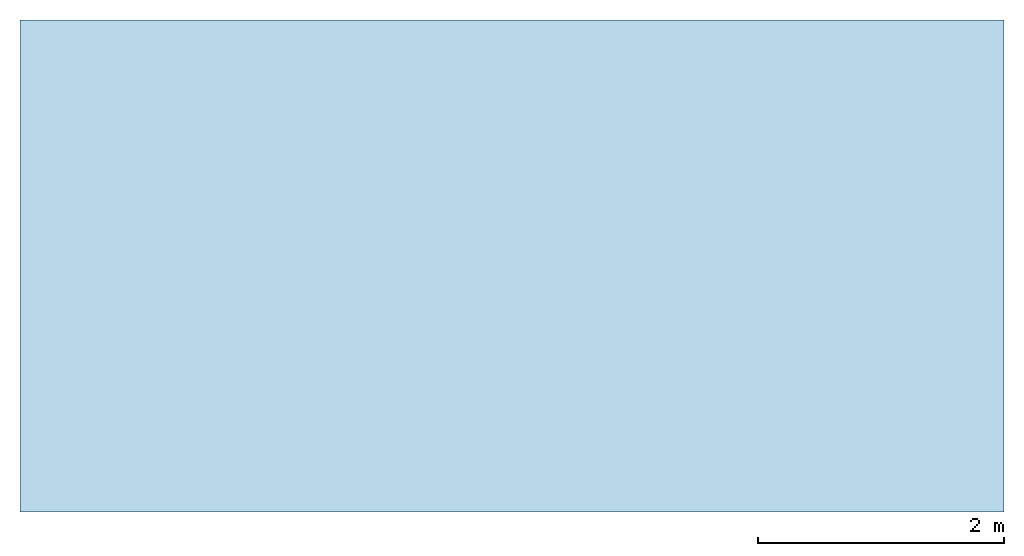
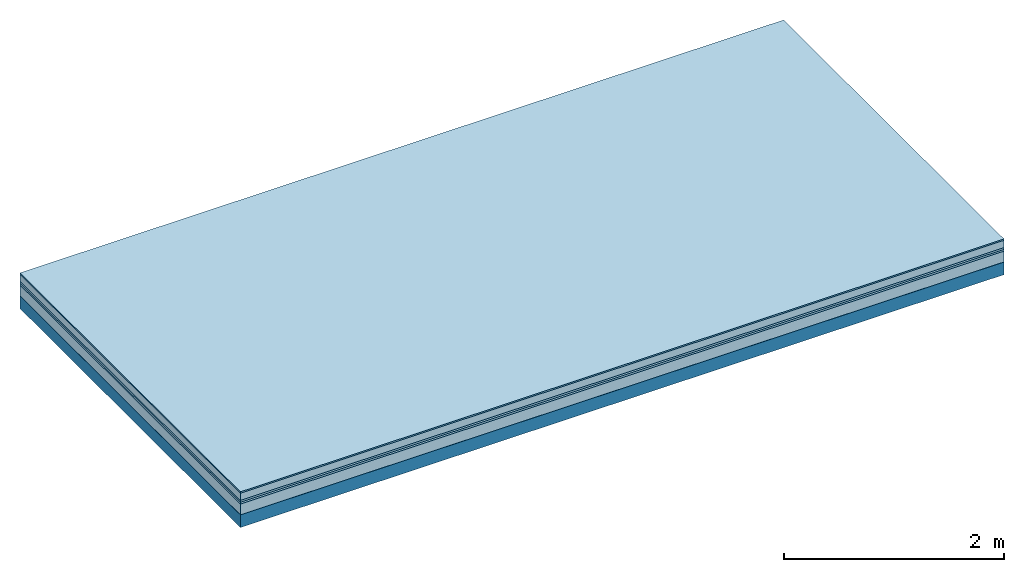
# One storey: 6 plates, 1 member, 1 element without a shape of its own.
"""IFC4 building model written with IfcOpenShell, lengths in metres."""

from ifc_helpers import new_model, si_unit, derived_unit, direction, frame, frame_2d, origin, origin_with_axes, place, context, project, spatial, rectangle, extrude, material, layer, layer_set, type_object, element, aggregate, save


model = new_model("IFC4")

# Units and contexts
plan_context = context("Plan", 3, precision=1e-05, world=origin(), true_north=direction((0.0, 1.0)))
model_context = context("Model", 3, precision=1e-05, world=origin(), true_north=direction((0.0, 1.0)))
ifc_project = project(units=[si_unit("LENGTHUNIT", "METRE"), derived_unit("SOUNDPRESSUREUNIT", [(si_unit("PRESSUREUNIT", "PASCAL", prefix="MICRO"), 0)]), si_unit("ENERGYUNIT", "JOULE", prefix="MEGA"), si_unit("MASSUNIT", "GRAM", prefix="KILO"), derived_unit("THERMALTRANSMITTANCEUNIT", [(si_unit("POWERUNIT", "WATT"), 1), (si_unit("AREAUNIT", "SQUARE_METRE"), -1), (si_unit("THERMODYNAMICTEMPERATUREUNIT", "KELVIN"), -1)]), derived_unit("AREADENSITYUNIT", [(si_unit("MASSUNIT", "GRAM", prefix="KILO"), 1), (si_unit("AREAUNIT", "SQUARE_METRE"), -1)]), derived_unit("USERDEFINED", [(si_unit("ENERGYUNIT", "JOULE", prefix="MEGA"), 1), (si_unit("AREAUNIT", "SQUARE_METRE"), -1)])], contexts=[plan_context, model_context])

# Site, building, storey
site = spatial("IfcSite", under=ifc_project)
building_placement = place(None, origin())
building = spatial("IfcBuilding", under=site, at=building_placement)
storey_placement = place(building_placement, origin())
storey = spatial("IfcBuildingStorey", under=building, at=storey_placement)

# Slab, member, plates
ifc_material_1 = material(Category="11.013")
ifc_layer_1 = layer(ifc_material_1, 0.015, Name="Flooring")
ifc_material_2 = material(Name="Cement screed", Category="04.006")
ifc_layer_2 = layer(ifc_material_2, 0.08, Name="On-material")
ifc_material_3 = material(Name="Wood fiber generic product", Category="10.009")
ifc_layer_3 = layer(ifc_material_3, 0.02, Name="Impact sound insulation")
ifc_material_4 = material()
ifc_layer_4 = layer(ifc_material_4, 0.02, Name="Additional insulation")
ifc_material_5 = material(Category="03.011")
ifc_layer_5 = layer(ifc_material_5, 0.12, Name="on Supporting structure")
ifc_material_6 = material(Name="protection", Category="09.007")
ifc_layer_6 = layer(ifc_material_6, 0.0005, Name="Sub-floor")
ifc_material_7 = material(Name="no composite action")
ifc_layer_7 = layer(ifc_material_7, 0.0, Name="Bond")
ifc_layer_8 = layer(None, 0.14, Name="Supporting structure")
ifc_layer_set = layer_set([ifc_layer_1, ifc_layer_2, ifc_layer_3, ifc_layer_4, ifc_layer_5, ifc_layer_6, ifc_layer_7, ifc_layer_8])
slab_type = type_object("IfcSlabType", Name="A2079", PredefinedType="NOTDEFINED", material=ifc_layer_set)
slab_placement = place(None, frame((0.0, 0.0, 0.0), z_axis=(0.0, 0.0, -1.0), x_axis=(1.0, 0.0, 0.0)))
slab = element("IfcSlab", 1, at=slab_placement, inside=storey, type_object=slab_type, material=ifc_layer_set, Name="Slab #1")
ifc_material_8 = material(Name="Solid timber panel")
member_placement = place(slab_placement, origin())
member = element("IfcMember", 2, at=member_placement, material=ifc_material_8, Name="Supporting structure", context=plan_context, shape_type="SweptSolid", body=[
    extrude(rectangle(XDim=1.0, YDim=0.14, at=frame_2d((0.5, 0.07), x_axis=(1.0, 0.0))), frame((0.0, 4.0, 0.2555), z_axis=(0.0, -1.0, 0.0), x_axis=(1.0, 0.0, 0.0)), (0.0, 0.0, 1.0), 4.0),
    extrude(rectangle(XDim=1.0, YDim=0.14, at=frame_2d((0.5, 0.07), x_axis=(1.0, 0.0))), frame((1.0, 4.0, 0.2555), z_axis=(0.0, -1.0, 0.0), x_axis=(1.0, 0.0, 0.0)), (0.0, 0.0, 1.0), 4.0),
    extrude(rectangle(XDim=1.0, YDim=0.14, at=frame_2d((0.5, 0.07), x_axis=(1.0, 0.0))), frame((2.0, 4.0, 0.2555), z_axis=(0.0, -1.0, 0.0), x_axis=(1.0, 0.0, 0.0)), (0.0, 0.0, 1.0), 4.0),
    extrude(rectangle(XDim=1.0, YDim=0.14, at=frame_2d((0.5, 0.07), x_axis=(1.0, 0.0))), frame((3.0, 4.0, 0.2555), z_axis=(0.0, -1.0, 0.0), x_axis=(1.0, 0.0, 0.0)), (0.0, 0.0, 1.0), 4.0),
    extrude(rectangle(XDim=1.0, YDim=0.14, at=frame_2d((0.5, 0.07), x_axis=(1.0, 0.0))), frame((4.0, 4.0, 0.2555), z_axis=(0.0, -1.0, 0.0), x_axis=(1.0, 0.0, 0.0)), (0.0, 0.0, 1.0), 4.0),
    extrude(rectangle(XDim=1.0, YDim=0.14, at=frame_2d((0.5, 0.07), x_axis=(1.0, 0.0))), frame((5.0, 4.0, 0.2555), z_axis=(0.0, -1.0, 0.0), x_axis=(1.0, 0.0, 0.0)), (0.0, 0.0, 1.0), 4.0),
    extrude(rectangle(XDim=1.0, YDim=0.14, at=frame_2d((0.5, 0.07), x_axis=(1.0, 0.0))), frame((6.0, 4.0, 0.2555), z_axis=(0.0, -1.0, 0.0), x_axis=(1.0, 0.0, 0.0)), (0.0, 0.0, 1.0), 4.0),
    extrude(rectangle(XDim=1.0, YDim=0.14, at=frame_2d((0.5, 0.07), x_axis=(1.0, 0.0))), frame((7.0, 4.0, 0.2555), z_axis=(0.0, -1.0, 0.0), x_axis=(1.0, 0.0, 0.0)), (0.0, 0.0, 1.0), 4.0),
])
plate_1_placement = place(slab_placement, origin())
plate_1 = element("IfcPlate", 3, at=plate_1_placement, material=ifc_material_1, Name="Flooring", context=plan_context, shape_type="SweptSolid", body=[
    extrude(rectangle(XDim=8.0, YDim=4.0, at=frame_2d((4.0, 2.0), x_axis=(1.0, 0.0))), origin_with_axes(), (0.0, 0.0, 1.0), 0.015),
])
plate_2_placement = place(slab_placement, origin())
plate_2 = element("IfcPlate", 4, at=plate_2_placement, material=ifc_material_2, Name="On-material", context=plan_context, shape_type="SweptSolid", body=[
    extrude(rectangle(XDim=8.0, YDim=4.0, at=frame_2d((4.0, 2.0), x_axis=(1.0, 0.0))), frame((0.0, 0.0, 0.015), z_axis=(0.0, 0.0, 1.0), x_axis=(1.0, 0.0, 0.0)), (0.0, 0.0, 1.0), 0.08),
])
plate_3_placement = place(slab_placement, origin())
plate_3 = element("IfcPlate", 5, at=plate_3_placement, material=ifc_material_3, Name="Impact sound insulation", context=plan_context, shape_type="SweptSolid", body=[
    extrude(rectangle(XDim=8.0, YDim=4.0, at=frame_2d((4.0, 2.0), x_axis=(1.0, 0.0))), frame((0.0, 0.0, 0.095), z_axis=(0.0, 0.0, 1.0), x_axis=(1.0, 0.0, 0.0)), (0.0, 0.0, 1.0), 0.02),
])
plate_4_placement = place(slab_placement, origin())
plate_4 = element("IfcPlate", 6, at=plate_4_placement, material=ifc_material_4, Name="Additional insulation", context=plan_context, shape_type="SweptSolid", body=[
    extrude(rectangle(XDim=8.0, YDim=4.0, at=frame_2d((4.0, 2.0), x_axis=(1.0, 0.0))), frame((0.0, 0.0, 0.115), z_axis=(0.0, 0.0, 1.0), x_axis=(1.0, 0.0, 0.0)), (0.0, 0.0, 1.0), 0.02),
])
plate_5_placement = place(slab_placement, origin())
plate_5 = element("IfcPlate", 7, at=plate_5_placement, material=ifc_material_5, Name="on Supporting structure", context=plan_context, shape_type="SweptSolid", body=[
    extrude(rectangle(XDim=8.0, YDim=4.0, at=frame_2d((4.0, 2.0), x_axis=(1.0, 0.0))), frame((0.0, 0.0, 0.135), z_axis=(0.0, 0.0, 1.0), x_axis=(1.0, 0.0, 0.0)), (0.0, 0.0, 1.0), 0.12),
])
plate_6_placement = place(slab_placement, origin())
plate_6 = element("IfcPlate", 8, at=plate_6_placement, material=ifc_material_6, Name="Sub-floor", context=plan_context, shape_type="SweptSolid", body=[
    extrude(rectangle(XDim=8.0, YDim=4.0, at=frame_2d((4.0, 2.0), x_axis=(1.0, 0.0))), frame((0.0, 0.0, 0.255), z_axis=(0.0, 0.0, 1.0), x_axis=(1.0, 0.0, 0.0)), (0.0, 0.0, 1.0), 0.0005),
])
aggregate(slab, [plate_1, plate_2, plate_3, plate_4, plate_5, plate_6, member])

save(model, "model.ifc")
